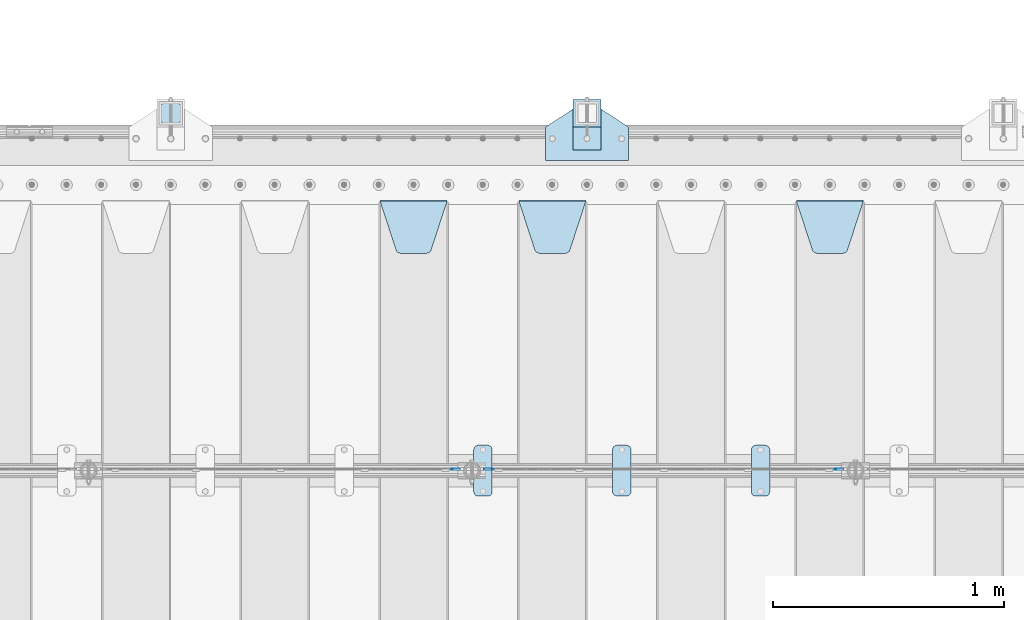
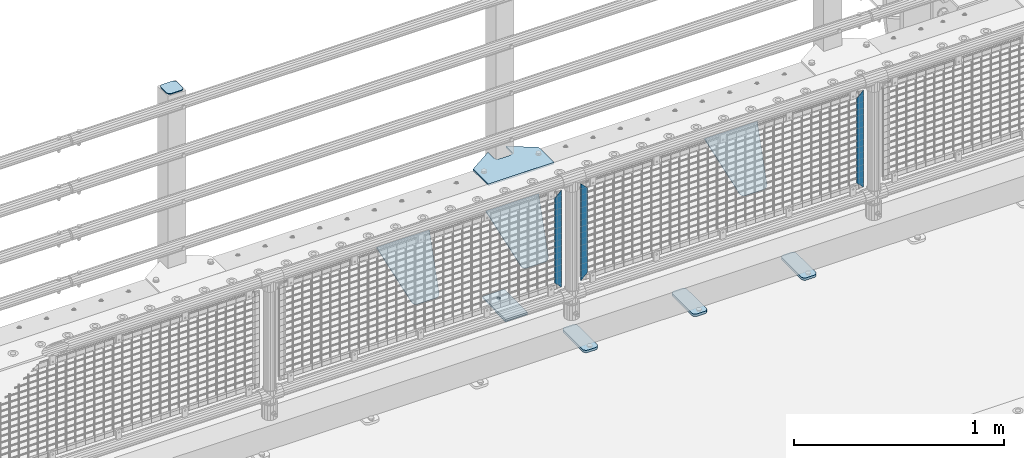
# One storey, part 198 of 219: 13 plates.
"""IFC2X3 building model written with IfcOpenShell, lengths in millimetres."""

from ifc_helpers import new_model, si_unit, frame, origin_with_axes, place, context, subcontext, project, spatial, faceted_brep, material, type_object, element, save


model = new_model("IFC2X3")

# Units and contexts
model_context = context("Model", 3, precision=1e-05, world=origin_with_axes())
body_context = subcontext(model_context, "Body", "Model", "MODEL_VIEW")
ifc_project = project(units=[si_unit("LENGTHUNIT", "METRE", prefix="MILLI"), si_unit("AREAUNIT", "SQUARE_METRE"), si_unit("VOLUMEUNIT", "CUBIC_METRE"), si_unit("MASSUNIT", "GRAM", prefix="KILO"), si_unit("TIMEUNIT", "SECOND"), si_unit("PLANEANGLEUNIT", "RADIAN"), si_unit("SOLIDANGLEUNIT", "STERADIAN"), si_unit("THERMODYNAMICTEMPERATUREUNIT", "DEGREE_CELSIUS"), si_unit("LUMINOUSINTENSITYUNIT", "LUMEN")], contexts=[model_context])

# Site, building, storey
site_placement = place(None, origin_with_axes())
site = spatial("IfcSite", under=ifc_project, at=site_placement, CompositionType="ELEMENT")
building_placement = place(site_placement, origin_with_axes())
building = spatial("IfcBuilding", under=site, at=building_placement, Name="Standard", CompositionType="ELEMENT")
storey_placement = place(building_placement, origin_with_axes())
storey = spatial("IfcBuildingStorey", under=building, at=storey_placement, Name="Undefined", CompositionType="ELEMENT", Elevation=0.0)

# Plates
ifc_material_1 = material(Name="STEEL/S355N")
plate_type_1 = type_object("IfcPlateType", PredefinedType="NOTDEFINED")
plate_1_placement = place(storey_placement, frame((8655.0, 32831.767766956, -1.76776695296758), z_axis=(0.0, -0.707106781186547, -0.707106781186548), x_axis=(1.0, 0.0, 0.0)))
element("IfcPlate", 1, at=plate_1_placement, inside=storey, type_object=plate_type_1, material=ifc_material_1, context=body_context, shape_type="Brep", body=[
    faceted_brep([(0.0, -2.5, 0.0), (69.345504679477, -2.5, 300.171731424834), (69.345504679477, 2.49999999999636, 300.171731424831), (0.0, 2.5, 0.0), (70.9274061199576, -2.50000000000364, 304.8974424154), (70.9274061199576, 2.49999999999636, 304.8974424154), (73.3818627772307, -2.50000000000364, 309.234538108532), (73.3818627772307, 2.49999999999636, 309.234538108532), (76.6187032999569, -2.50000000000364, 313.023683126106), (76.6187032999569, 2.49999999999636, 313.023683126106), (80.5190132704993, -2.50000000000364, 316.125672595372), (80.5190132704993, 2.49999999999636, 316.125672595372), (84.9395038596831, -2.50000000000364, 318.426546230476), (84.9395038596831, 2.5, 318.426546230479), (89.7177759439237, -2.50000000000364, 319.841774983277), (89.7177759439237, 2.5, 319.841774983281), (94.6782862926502, -2.50000000000364, 320.319366455078), (94.6782862926502, 2.49999999999636, 320.319366455078), (195.32171370735, -2.50000000000364, 320.319366455078), (195.32171370735, 2.49999999999636, 320.319366455078), (200.282224056076, -2.50000000000364, 319.841774983277), (200.282224056076, 2.5, 319.841774983281), (205.060496140317, -2.50000000000364, 318.426546230476), (205.060496140317, 2.49999999999636, 318.426546230476), (209.480986729501, -2.50000000000364, 316.125672595372), (209.480986729501, 2.49999999999636, 316.125672595372), (213.381296700043, -2.50000000000364, 313.023683126106), (213.381296700043, 2.49999999999272, 313.023683126106), (216.618137222769, -2.50000000000364, 309.234538108529), (216.618137222769, 2.49999999999636, 309.234538108525), (219.072593880042, -2.50000000000364, 304.8974424154), (219.072593880042, 2.49999999999636, 304.8974424154), (220.654495320523, -2.5, 300.171731424834), (220.654495320523, 2.49999999999636, 300.171731424831), (290.0, -2.50000000000364, 3.63797880709171e-12), (290.0, 2.49999999999636, 0.0)], [[[0, 1, 2, 3]], [[1, 4, 5, 2]], [[4, 6, 7, 5]], [[6, 8, 9, 7]], [[8, 10, 11, 9]], [[10, 12, 13, 11]], [[12, 14, 15, 13]], [[14, 16, 17, 15]], [[16, 18, 19, 17]], [[18, 20, 21, 19]], [[20, 22, 23, 21]], [[22, 24, 25, 23]], [[24, 26, 27, 25]], [[26, 28, 29, 27]], [[28, 30, 31, 29]], [[30, 32, 33, 31]], [[32, 34, 35, 33]], [[34, 0, 3, 35]], [[5, 7, 9, 11, 13, 15, 17, 19, 21, 23, 25, 27, 29, 31, 33, 35, 3, 2]], [[34, 32, 30, 28, 26, 24, 22, 20, 18, 16, 14, 12, 10, 8, 6, 4, 1, 0]]]),
])
plate_2_placement = place(storey_placement, frame((7455.0, 32831.767766956, -1.76776695296758), z_axis=(0.0, -0.707106781186547, -0.707106781186548), x_axis=(1.0, 0.0, 0.0)))
element("IfcPlate", 2, at=plate_2_placement, inside=storey, type_object=plate_type_1, material=ifc_material_1, context=body_context, shape_type="Brep", body=[
    faceted_brep([(0.0, -2.5, 0.0), (69.345504679477, -2.5, 300.171731424834), (69.345504679477, 2.49999999999636, 300.171731424831), (0.0, 2.5, 0.0), (70.9274061199576, -2.50000000000364, 304.8974424154), (70.9274061199576, 2.49999999999636, 304.8974424154), (73.3818627772307, -2.50000000000364, 309.234538108532), (73.3818627772307, 2.49999999999636, 309.234538108532), (76.6187032999569, -2.50000000000364, 313.023683126106), (76.6187032999569, 2.49999999999636, 313.023683126106), (80.5190132704993, -2.50000000000364, 316.125672595372), (80.5190132704993, 2.49999999999636, 316.125672595372), (84.9395038596831, -2.50000000000364, 318.426546230476), (84.9395038596831, 2.5, 318.426546230479), (89.7177759439237, -2.50000000000364, 319.841774983277), (89.7177759439237, 2.5, 319.841774983281), (94.6782862926502, -2.50000000000364, 320.319366455078), (94.6782862926502, 2.49999999999636, 320.319366455078), (195.32171370735, -2.50000000000364, 320.319366455078), (195.32171370735, 2.49999999999636, 320.319366455078), (200.282224056076, -2.50000000000364, 319.841774983277), (200.282224056076, 2.5, 319.841774983281), (205.060496140317, -2.50000000000364, 318.426546230476), (205.060496140317, 2.49999999999636, 318.426546230476), (209.480986729501, -2.50000000000364, 316.125672595372), (209.480986729501, 2.49999999999636, 316.125672595372), (213.381296700043, -2.50000000000364, 313.023683126106), (213.381296700043, 2.49999999999272, 313.023683126106), (216.618137222769, -2.50000000000364, 309.234538108529), (216.618137222769, 2.49999999999636, 309.234538108525), (219.072593880042, -2.50000000000364, 304.8974424154), (219.072593880042, 2.49999999999636, 304.8974424154), (220.654495320523, -2.5, 300.171731424834), (220.654495320523, 2.49999999999636, 300.171731424831), (290.0, -2.50000000000364, 3.63797880709171e-12), (290.0, 2.49999999999636, 0.0)], [[[0, 1, 2, 3]], [[1, 4, 5, 2]], [[4, 6, 7, 5]], [[6, 8, 9, 7]], [[8, 10, 11, 9]], [[10, 12, 13, 11]], [[12, 14, 15, 13]], [[14, 16, 17, 15]], [[16, 18, 19, 17]], [[18, 20, 21, 19]], [[20, 22, 23, 21]], [[22, 24, 25, 23]], [[24, 26, 27, 25]], [[26, 28, 29, 27]], [[28, 30, 31, 29]], [[30, 32, 33, 31]], [[32, 34, 35, 33]], [[34, 0, 3, 35]], [[5, 7, 9, 11, 13, 15, 17, 19, 21, 23, 25, 27, 29, 31, 33, 35, 3, 2]], [[34, 32, 30, 28, 26, 24, 22, 20, 18, 16, 14, 12, 10, 8, 6, 4, 1, 0]]]),
])
plate_3_placement = place(storey_placement, frame((6855.0, 32831.767766956, -1.76776695296758), z_axis=(0.0, -0.707106781186547, -0.707106781186548), x_axis=(1.0, 0.0, 0.0)))
element("IfcPlate", 3, at=plate_3_placement, inside=storey, type_object=plate_type_1, material=ifc_material_1, context=body_context, shape_type="Brep", body=[
    faceted_brep([(0.0, -2.5, 0.0), (69.345504679477, -2.5, 300.171731424834), (69.345504679477, 2.49999999999636, 300.171731424831), (0.0, 2.5, 0.0), (70.9274061199576, -2.50000000000364, 304.8974424154), (70.9274061199576, 2.49999999999636, 304.8974424154), (73.3818627772307, -2.50000000000364, 309.234538108532), (73.3818627772307, 2.49999999999636, 309.234538108532), (76.6187032999569, -2.50000000000364, 313.023683126106), (76.6187032999569, 2.49999999999636, 313.023683126106), (80.5190132704993, -2.50000000000364, 316.125672595372), (80.5190132704993, 2.49999999999636, 316.125672595372), (84.9395038596831, -2.50000000000364, 318.426546230476), (84.9395038596831, 2.5, 318.426546230479), (89.7177759439237, -2.50000000000364, 319.841774983277), (89.7177759439237, 2.5, 319.841774983281), (94.6782862926502, -2.50000000000364, 320.319366455078), (94.6782862926502, 2.49999999999636, 320.319366455078), (195.32171370735, -2.50000000000364, 320.319366455078), (195.32171370735, 2.49999999999636, 320.319366455078), (200.282224056076, -2.50000000000364, 319.841774983277), (200.282224056076, 2.5, 319.841774983281), (205.060496140317, -2.50000000000364, 318.426546230476), (205.060496140317, 2.49999999999636, 318.426546230476), (209.480986729501, -2.50000000000364, 316.125672595372), (209.480986729501, 2.49999999999636, 316.125672595372), (213.381296700043, -2.50000000000364, 313.023683126106), (213.381296700043, 2.49999999999272, 313.023683126106), (216.618137222769, -2.50000000000364, 309.234538108529), (216.618137222769, 2.49999999999636, 309.234538108525), (219.072593880042, -2.50000000000364, 304.8974424154), (219.072593880042, 2.49999999999636, 304.8974424154), (220.654495320523, -2.5, 300.171731424834), (220.654495320523, 2.49999999999636, 300.171731424831), (290.0, -2.50000000000364, 3.63797880709171e-12), (290.0, 2.49999999999636, 0.0)], [[[0, 1, 2, 3]], [[1, 4, 5, 2]], [[4, 6, 7, 5]], [[6, 8, 9, 7]], [[8, 10, 11, 9]], [[10, 12, 13, 11]], [[12, 14, 15, 13]], [[14, 16, 17, 15]], [[16, 18, 19, 17]], [[18, 20, 21, 19]], [[20, 22, 23, 21]], [[22, 24, 25, 23]], [[24, 26, 27, 25]], [[26, 28, 29, 27]], [[28, 30, 31, 29]], [[30, 32, 33, 31]], [[32, 34, 35, 33]], [[34, 0, 3, 35]], [[5, 7, 9, 11, 13, 15, 17, 19, 21, 23, 25, 27, 29, 31, 33, 35, 3, 2]], [[34, 32, 30, 28, 26, 24, 22, 20, 18, 16, 14, 12, 10, 8, 6, 4, 1, 0]]]),
])
ifc_material_2 = material(Name="Misc_Undefined")
plate_type_2 = type_object("IfcPlateType", PredefinedType="NOTDEFINED")
plate_4_placement = place(storey_placement, frame((7341.50971354097, 31670.5, 879.519963133601), z_axis=(-0.707008801899319, 0.0, -0.707204746899291), x_axis=(-0.707204746899285, 0.0, 0.707008801899324)))
element("IfcPlate", 4, at=plate_4_placement, inside=storey, type_object=plate_type_2, material=ifc_material_2, context=body_context, shape_type="Brep", body=[
    faceted_brep([(0.0, -1.5, -5.6843418860808e-14), (-348.552185058593, -1.5, 348.655029296875), (-348.552185058593, 1.5, 348.655029296875), (0.0, 1.5, -5.6843418860808e-14), (-348.544891357421, -1.5, 398.152496337892), (-348.544891357421, 1.5, 398.152496337892), (49.5043945312482, -1.5, 7.6397554948926e-11), (49.5043945312482, 1.5, 7.6397554948926e-11)], [[[0, 1, 2, 3]], [[1, 4, 5, 2]], [[4, 6, 7, 5]], [[6, 0, 3, 7]], [[5, 7, 3, 2]], [[6, 4, 1, 0]]]),
])
for number, where, z_axis, x_axis in (
    (5, (8822.49968748361, 31670.5, 879.52), (0.707103624179499, 0.0, -0.707109938179501), (0.707109938179499, 0.0, 0.707103624179502)),
    (6, (7164.49968748361, 31670.5, 879.52), (0.707103624179499, 0.0, -0.707109938179501), (0.707109938179499, 0.0, 0.707103624179502)),
):
    element("IfcPlate", number, at=place(storey_placement, frame(where, z_axis=z_axis, x_axis=x_axis)), inside=storey, type_object=plate_type_2, material=ifc_material_2, context=body_context, shape_type="Brep", body=[
        faceted_brep([(0.0, -1.5, -5.6843418860808e-14), (-348.605163574219, -1.5, 348.602081298829), (-348.605163574219, 1.5, 348.602081298829), (0.0, 1.5, -5.6843418860808e-14), (-348.605163574217, -1.5, 398.0993347168), (-348.605163574217, 1.5, 398.0993347168), (49.4976959228516, -1.5, -1.0550138540566e-10), (49.4976959228516, 1.5, -1.0550138540566e-10)], [[[0, 1, 2, 3]], [[1, 4, 5, 2]], [[4, 6, 7, 5]], [[6, 0, 3, 7]], [[5, 7, 3, 2]], [[6, 4, 1, 0]]]),
    ])
ifc_material_3 = material(Name="STEEL/S355J2")
plate_type_3 = type_object("IfcPlateType", PredefinedType="NOTDEFINED")
plate_5_placement = place(storey_placement, frame((8460.0, 31774.5, 21.0199999999977), z_axis=(1.0, 0.0, 0.0), x_axis=(0.0, -1.0, 0.0)))
element("IfcPlate", 7, at=plate_5_placement, inside=storey, type_object=plate_type_3, material=ifc_material_3, context=body_context, shape_type="Brep", body=[
    faceted_brep([(0.0, -7.0, 20.0), (0.0, -7.0, 60.0), (0.0, 7.0, 60.0), (0.0, 7.0, 20.0), (0.384294391937146, -7.0, 63.9018064403226), (0.384294391937146, 7.0, 63.9018064403226), (1.52240934977453, -7.0, 67.6536686473009), (1.52240934977453, 7.0, 67.6536686473009), (3.37060775395003, -7.0, 71.1114046603925), (3.37060775395003, 7.0, 71.1114046603925), (5.8578643762703, -7.0, 74.1421356237315), (5.8578643762703, 7.0, 74.1421356237315), (8.88859533960931, -7.0, 76.6293922460518), (8.88859533960931, 7.0, 76.6293922460518), (12.3463313526991, -7.0, 78.4775906502255), (12.3463313526991, 7.0, 78.4775906502255), (16.0981935596792, -7.0, 79.6157056080647), (16.0981935596792, 7.0, 79.6157056080647), (20.0, -7.0, 80.0), (20.0, 7.0, 80.0), (200.0, -7.0, 80.0), (200.0, 7.0, 80.0), (203.901806440321, -7.0, 79.6157056080647), (203.901806440321, 7.0, 79.6157056080647), (207.653668647301, -7.0, 78.4775906502255), (207.653668647301, 7.0, 78.4775906502255), (211.111404660391, -7.0, 76.6293922460518), (211.111404660391, 7.0, 76.6293922460518), (214.14213562373, -7.0, 74.1421356237315), (214.14213562373, 7.0, 74.1421356237315), (216.62939224605, -7.0, 71.1114046603925), (216.62939224605, 7.0, 71.1114046603925), (218.477590650225, -7.0, 67.6536686473009), (218.477590650225, 7.0, 67.6536686473009), (219.615705608063, -7.0, 63.9018064403226), (219.615705608063, 7.0, 63.9018064403226), (220.0, -7.0, 60.0), (220.0, 7.0, 60.0), (220.0, -7.0, 20.0), (220.0, 7.0, 20.0), (219.615705608063, -7.0, 16.0981935596774), (219.615705608063, 7.0, 16.0981935596774), (218.477590650225, -7.0, 12.3463313526991), (218.477590650225, 7.0, 12.3463313526991), (216.62939224605, -7.0, 8.88859533960749), (216.62939224605, 7.0, 8.88859533960749), (214.14213562373, -7.0, 5.85786437626848), (214.14213562373, 7.0, 5.85786437626848), (211.111404660391, -7.0, 3.37060775394821), (211.111404660391, 7.0, 3.37060775394821), (207.653668647301, -7.0, 1.52240934977453), (207.653668647301, 7.0, 1.52240934977453), (203.901806440321, -7.0, 0.384294391935327), (203.901806440321, 7.0, 0.384294391935327), (200.0, -7.0, 0.0), (200.0, 7.0, 0.0), (20.0, -7.0, 0.0), (20.0, 7.0, 0.0), (16.0981935596792, -7.0, 0.384294391935327), (16.0981935596792, 7.0, 0.384294391935327), (12.3463313526991, -7.0, 1.52240934977453), (12.3463313526991, 7.0, 1.52240934977453), (8.88859533960931, -7.0, 3.37060775394821), (8.88859533960931, 7.0, 3.37060775394821), (5.8578643762703, -7.0, 5.85786437626848), (5.8578643762703, 7.0, 5.85786437626848), (3.37060775395003, -7.0, 8.88859533960749), (3.37060775395003, 7.0, 8.88859533960749), (1.52240934977453, -7.0, 12.3463313526991), (1.52240934977453, 7.0, 12.3463313526991), (0.384294391937146, -7.0, 16.0981935596774), (0.384294391937146, 7.0, 16.0981935596774)], [[[0, 1, 2, 3]], [[1, 4, 5, 2]], [[4, 6, 7, 5]], [[6, 8, 9, 7]], [[8, 10, 11, 9]], [[10, 12, 13, 11]], [[12, 14, 15, 13]], [[14, 16, 17, 15]], [[16, 18, 19, 17]], [[18, 20, 21, 19]], [[20, 22, 23, 21]], [[22, 24, 25, 23]], [[24, 26, 27, 25]], [[26, 28, 29, 27]], [[28, 30, 31, 29]], [[30, 32, 33, 31]], [[32, 34, 35, 33]], [[34, 36, 37, 35]], [[36, 38, 39, 37]], [[38, 40, 41, 39]], [[40, 42, 43, 41]], [[42, 44, 45, 43]], [[44, 46, 47, 45]], [[46, 48, 49, 47]], [[48, 50, 51, 49]], [[50, 52, 53, 51]], [[52, 54, 55, 53]], [[54, 56, 57, 55]], [[56, 58, 59, 57]], [[58, 60, 61, 59]], [[60, 62, 63, 61]], [[62, 64, 65, 63]], [[64, 66, 67, 65]], [[66, 68, 69, 67]], [[68, 70, 71, 69]], [[70, 0, 3, 71]], [[5, 7, 9, 11, 13, 15, 17, 19, 21, 23, 25, 27, 29, 31, 33, 35, 37, 39, 41, 43, 45, 47, 49, 51, 53, 55, 57, 59, 61, 63, 65, 67, 69, 71, 3, 2]], [[70, 68, 66, 64, 62, 60, 58, 56, 54, 52, 50, 48, 46, 44, 42, 40, 38, 36, 34, 32, 30, 28, 26, 24, 22, 20, 18, 16, 14, 12, 10, 8, 6, 4, 1, 0]]]),
])
plate_6_placement = place(storey_placement, frame((7860.0, 31774.5, 21.0199999999977), z_axis=(1.0, 0.0, 0.0), x_axis=(0.0, -1.0, 0.0)))
element("IfcPlate", 8, at=plate_6_placement, inside=storey, type_object=plate_type_3, material=ifc_material_3, context=body_context, shape_type="Brep", body=[
    faceted_brep([(0.0, -7.0, 20.0), (0.0, -7.0, 60.0), (0.0, 7.0, 60.0), (0.0, 7.0, 20.0), (0.384294391937146, -7.0, 63.9018064403226), (0.384294391937146, 7.0, 63.9018064403226), (1.52240934977453, -7.0, 67.6536686473009), (1.52240934977453, 7.0, 67.6536686473009), (3.37060775395003, -7.0, 71.1114046603925), (3.37060775395003, 7.0, 71.1114046603925), (5.8578643762703, -7.0, 74.1421356237315), (5.8578643762703, 7.0, 74.1421356237315), (8.88859533960931, -7.0, 76.6293922460518), (8.88859533960931, 7.0, 76.6293922460518), (12.3463313526991, -7.0, 78.4775906502255), (12.3463313526991, 7.0, 78.4775906502255), (16.0981935596792, -7.0, 79.6157056080647), (16.0981935596792, 7.0, 79.6157056080647), (20.0, -7.0, 80.0), (20.0, 7.0, 80.0), (200.0, -7.0, 80.0), (200.0, 7.0, 80.0), (203.901806440321, -7.0, 79.6157056080647), (203.901806440321, 7.0, 79.6157056080647), (207.653668647301, -7.0, 78.4775906502255), (207.653668647301, 7.0, 78.4775906502255), (211.111404660391, -7.0, 76.6293922460518), (211.111404660391, 7.0, 76.6293922460518), (214.14213562373, -7.0, 74.1421356237315), (214.14213562373, 7.0, 74.1421356237315), (216.62939224605, -7.0, 71.1114046603925), (216.62939224605, 7.0, 71.1114046603925), (218.477590650225, -7.0, 67.6536686473009), (218.477590650225, 7.0, 67.6536686473009), (219.615705608063, -7.0, 63.9018064403226), (219.615705608063, 7.0, 63.9018064403226), (220.0, -7.0, 60.0), (220.0, 7.0, 60.0), (220.0, -7.0, 20.0), (220.0, 7.0, 20.0), (219.615705608063, -7.0, 16.0981935596774), (219.615705608063, 7.0, 16.0981935596774), (218.477590650225, -7.0, 12.3463313526991), (218.477590650225, 7.0, 12.3463313526991), (216.62939224605, -7.0, 8.88859533960749), (216.62939224605, 7.0, 8.88859533960749), (214.14213562373, -7.0, 5.85786437626848), (214.14213562373, 7.0, 5.85786437626848), (211.111404660391, -7.0, 3.37060775394821), (211.111404660391, 7.0, 3.37060775394821), (207.653668647301, -7.0, 1.52240934977453), (207.653668647301, 7.0, 1.52240934977453), (203.901806440321, -7.0, 0.384294391935327), (203.901806440321, 7.0, 0.384294391935327), (200.0, -7.0, 0.0), (200.0, 7.0, 0.0), (20.0, -7.0, 0.0), (20.0, 7.0, 0.0), (16.0981935596792, -7.0, 0.384294391935327), (16.0981935596792, 7.0, 0.384294391935327), (12.3463313526991, -7.0, 1.52240934977453), (12.3463313526991, 7.0, 1.52240934977453), (8.88859533960931, -7.0, 3.37060775394821), (8.88859533960931, 7.0, 3.37060775394821), (5.8578643762703, -7.0, 5.85786437626848), (5.8578643762703, 7.0, 5.85786437626848), (3.37060775395003, -7.0, 8.88859533960749), (3.37060775395003, 7.0, 8.88859533960749), (1.52240934977453, -7.0, 12.3463313526991), (1.52240934977453, 7.0, 12.3463313526991), (0.384294391937146, -7.0, 16.0981935596774), (0.384294391937146, 7.0, 16.0981935596774)], [[[0, 1, 2, 3]], [[1, 4, 5, 2]], [[4, 6, 7, 5]], [[6, 8, 9, 7]], [[8, 10, 11, 9]], [[10, 12, 13, 11]], [[12, 14, 15, 13]], [[14, 16, 17, 15]], [[16, 18, 19, 17]], [[18, 20, 21, 19]], [[20, 22, 23, 21]], [[22, 24, 25, 23]], [[24, 26, 27, 25]], [[26, 28, 29, 27]], [[28, 30, 31, 29]], [[30, 32, 33, 31]], [[32, 34, 35, 33]], [[34, 36, 37, 35]], [[36, 38, 39, 37]], [[38, 40, 41, 39]], [[40, 42, 43, 41]], [[42, 44, 45, 43]], [[44, 46, 47, 45]], [[46, 48, 49, 47]], [[48, 50, 51, 49]], [[50, 52, 53, 51]], [[52, 54, 55, 53]], [[54, 56, 57, 55]], [[56, 58, 59, 57]], [[58, 60, 61, 59]], [[60, 62, 63, 61]], [[62, 64, 65, 63]], [[64, 66, 67, 65]], [[66, 68, 69, 67]], [[68, 70, 71, 69]], [[70, 0, 3, 71]], [[5, 7, 9, 11, 13, 15, 17, 19, 21, 23, 25, 27, 29, 31, 33, 35, 37, 39, 41, 43, 45, 47, 49, 51, 53, 55, 57, 59, 61, 63, 65, 67, 69, 71, 3, 2]], [[70, 68, 66, 64, 62, 60, 58, 56, 54, 52, 50, 48, 46, 44, 42, 40, 38, 36, 34, 32, 30, 28, 26, 24, 22, 20, 18, 16, 14, 12, 10, 8, 6, 4, 1, 0]]]),
])
plate_7_placement = place(storey_placement, frame((7260.0, 31774.5, 21.0199999999977), z_axis=(1.0, 0.0, 0.0), x_axis=(0.0, -1.0, 0.0)))
element("IfcPlate", 9, at=plate_7_placement, inside=storey, type_object=plate_type_3, material=ifc_material_3, context=body_context, shape_type="Brep", body=[
    faceted_brep([(0.0, -7.0, 20.0), (0.0, -7.0, 60.0), (0.0, 7.0, 60.0), (0.0, 7.0, 20.0), (0.384294391937146, -7.0, 63.9018064403226), (0.384294391937146, 7.0, 63.9018064403226), (1.52240934977453, -7.0, 67.6536686473009), (1.52240934977453, 7.0, 67.6536686473009), (3.37060775395003, -7.0, 71.1114046603925), (3.37060775395003, 7.0, 71.1114046603925), (5.8578643762703, -7.0, 74.1421356237315), (5.8578643762703, 7.0, 74.1421356237315), (8.88859533960931, -7.0, 76.6293922460518), (8.88859533960931, 7.0, 76.6293922460518), (12.3463313526991, -7.0, 78.4775906502255), (12.3463313526991, 7.0, 78.4775906502255), (16.0981935596792, -7.0, 79.6157056080647), (16.0981935596792, 7.0, 79.6157056080647), (20.0, -7.0, 80.0), (20.0, 7.0, 80.0), (200.0, -7.0, 80.0), (200.0, 7.0, 80.0), (203.901806440321, -7.0, 79.6157056080647), (203.901806440321, 7.0, 79.6157056080647), (207.653668647301, -7.0, 78.4775906502255), (207.653668647301, 7.0, 78.4775906502255), (211.111404660391, -7.0, 76.6293922460518), (211.111404660391, 7.0, 76.6293922460518), (214.14213562373, -7.0, 74.1421356237315), (214.14213562373, 7.0, 74.1421356237315), (216.62939224605, -7.0, 71.1114046603925), (216.62939224605, 7.0, 71.1114046603925), (218.477590650225, -7.0, 67.6536686473009), (218.477590650225, 7.0, 67.6536686473009), (219.615705608063, -7.0, 63.9018064403226), (219.615705608063, 7.0, 63.9018064403226), (220.0, -7.0, 60.0), (220.0, 7.0, 60.0), (220.0, -7.0, 20.0), (220.0, 7.0, 20.0), (219.615705608063, -7.0, 16.0981935596774), (219.615705608063, 7.0, 16.0981935596774), (218.477590650225, -7.0, 12.3463313526991), (218.477590650225, 7.0, 12.3463313526991), (216.62939224605, -7.0, 8.88859533960749), (216.62939224605, 7.0, 8.88859533960749), (214.14213562373, -7.0, 5.85786437626848), (214.14213562373, 7.0, 5.85786437626848), (211.111404660391, -7.0, 3.37060775394821), (211.111404660391, 7.0, 3.37060775394821), (207.653668647301, -7.0, 1.52240934977453), (207.653668647301, 7.0, 1.52240934977453), (203.901806440321, -7.0, 0.384294391935327), (203.901806440321, 7.0, 0.384294391935327), (200.0, -7.0, 0.0), (200.0, 7.0, 0.0), (20.0, -7.0, 0.0), (20.0, 7.0, 0.0), (16.0981935596792, -7.0, 0.384294391935327), (16.0981935596792, 7.0, 0.384294391935327), (12.3463313526991, -7.0, 1.52240934977453), (12.3463313526991, 7.0, 1.52240934977453), (8.88859533960931, -7.0, 3.37060775394821), (8.88859533960931, 7.0, 3.37060775394821), (5.8578643762703, -7.0, 5.85786437626848), (5.8578643762703, 7.0, 5.85786437626848), (3.37060775395003, -7.0, 8.88859533960749), (3.37060775395003, 7.0, 8.88859533960749), (1.52240934977453, -7.0, 12.3463313526991), (1.52240934977453, 7.0, 12.3463313526991), (0.384294391937146, -7.0, 16.0981935596774), (0.384294391937146, 7.0, 16.0981935596774)], [[[0, 1, 2, 3]], [[1, 4, 5, 2]], [[4, 6, 7, 5]], [[6, 8, 9, 7]], [[8, 10, 11, 9]], [[10, 12, 13, 11]], [[12, 14, 15, 13]], [[14, 16, 17, 15]], [[16, 18, 19, 17]], [[18, 20, 21, 19]], [[20, 22, 23, 21]], [[22, 24, 25, 23]], [[24, 26, 27, 25]], [[26, 28, 29, 27]], [[28, 30, 31, 29]], [[30, 32, 33, 31]], [[32, 34, 35, 33]], [[34, 36, 37, 35]], [[36, 38, 39, 37]], [[38, 40, 41, 39]], [[40, 42, 43, 41]], [[42, 44, 45, 43]], [[44, 46, 47, 45]], [[46, 48, 49, 47]], [[48, 50, 51, 49]], [[50, 52, 53, 51]], [[52, 54, 55, 53]], [[54, 56, 57, 55]], [[56, 58, 59, 57]], [[58, 60, 61, 59]], [[60, 62, 63, 61]], [[62, 64, 65, 63]], [[64, 66, 67, 65]], [[66, 68, 69, 67]], [[68, 70, 71, 69]], [[70, 0, 3, 71]], [[5, 7, 9, 11, 13, 15, 17, 19, 21, 23, 25, 27, 29, 31, 33, 35, 37, 39, 41, 43, 45, 47, 49, 51, 53, 55, 57, 59, 61, 63, 65, 67, 69, 71, 3, 2]], [[70, 68, 66, 64, 62, 60, 58, 56, 54, 52, 50, 48, 46, 44, 42, 40, 38, 36, 34, 32, 30, 28, 26, 24, 22, 20, 18, 16, 14, 12, 10, 8, 6, 4, 1, 0]]]),
])
plate_type_4 = type_object("IfcPlateType", PredefinedType="NOTDEFINED")
plate_8_placement = place(storey_placement, frame((7570.0, 33005.0, 5.00000000004911), z_axis=(0.0, 1.0, 0.0), x_axis=(1.0, 0.0, 0.0)))
element("IfcPlate", 10, at=plate_8_placement, inside=storey, type_object=plate_type_4, material=ifc_material_3, context=body_context, shape_type="Brep", body=[
    faceted_brep([(0.0, -5.0, 0.0), (2.31396552408114e-06, -5.0, 145.0), (2.31396552408114e-06, 5.0, 145.0), (0.0, 5.0, 0.0), (130.0, -5.0, 230.0), (130.0, 5.0, 230.0), (130.0, -5.0, 180.0), (130.0, 5.0, 180.0), (130.48036798992, -5.0, 175.122741949599), (130.48036798992, 5.0, 175.122741949599), (131.903011687218, -5.0, 170.432914190875), (131.903011687218, 5.0, 170.432914190875), (134.213259692437, -5.0, 166.110744174512), (134.213259692437, 5.0, 166.110744174512), (137.322330470337, -5.0, 162.322330470335), (137.322330470337, 5.0, 162.322330470335), (141.11074417451, -5.0, 159.213259692435), (141.11074417451, 5.0, 159.213259692435), (145.432914190873, -5.0, 156.903011687216), (145.432914190873, 5.0, 156.903011687216), (150.122741949597, -5.0, 155.48036798992), (150.122741949597, 5.0, 155.48036798992), (155.0, -5.0, 155.0), (155.0, 5.0, 155.0), (205.0, -5.0, 155.0), (205.0, 5.0, 155.0), (209.877258050403, -5.0, 155.48036798992), (209.877258050403, 5.0, 155.48036798992), (214.567085809127, -5.0, 156.903011687216), (214.567085809127, 5.0, 156.903011687216), (218.88925582549, -5.0, 159.213259692435), (218.88925582549, 5.0, 159.213259692435), (222.677669529663, -5.0, 162.322330470335), (222.677669529663, 5.0, 162.322330470335), (225.786740307563, -5.0, 166.110744174512), (225.786740307563, 5.0, 166.110744174512), (228.096988312782, -5.0, 170.432914190875), (228.096988312782, 5.0, 170.432914190875), (229.51963201008, -5.0, 175.122741949599), (229.51963201008, 5.0, 175.122741949599), (230.0, -5.0, 180.0), (230.0, 5.0, 180.0), (230.0, -5.0, 230.0), (230.0, 5.0, 230.0), (360.0, -5.0, 145.0), (360.0, 5.0, 145.0), (360.0, -5.0, -7.27595761418343e-12), (360.0, 5.0, -7.27595761418343e-12)], [[[0, 1, 2, 3]], [[1, 4, 5, 2]], [[4, 6, 7, 5]], [[6, 8, 9, 7]], [[8, 10, 11, 9]], [[10, 12, 13, 11]], [[12, 14, 15, 13]], [[14, 16, 17, 15]], [[16, 18, 19, 17]], [[18, 20, 21, 19]], [[20, 22, 23, 21]], [[22, 24, 25, 23]], [[24, 26, 27, 25]], [[26, 28, 29, 27]], [[28, 30, 31, 29]], [[30, 32, 33, 31]], [[32, 34, 35, 33]], [[34, 36, 37, 35]], [[36, 38, 39, 37]], [[38, 40, 41, 39]], [[40, 42, 43, 41]], [[42, 44, 45, 43]], [[44, 46, 47, 45]], [[46, 0, 3, 47]], [[5, 7, 9, 11, 13, 15, 17, 19, 21, 23, 25, 27, 29, 31, 33, 35, 37, 39, 41, 43, 45, 47, 3, 2]], [[46, 44, 42, 40, 38, 36, 34, 32, 30, 28, 26, 24, 22, 20, 18, 16, 14, 12, 10, 8, 6, 4, 1, 0]]]),
])
plate_type_5 = type_object("IfcPlateType", PredefinedType="NOTDEFINED")
plate_9_placement = place(storey_placement, frame((7690.00000000014, 33050.0000000002, -850.000000000002), z_axis=(0.0, 1.0, 0.0), x_axis=(1.0, 0.0, 0.0)))
element("IfcPlate", 11, at=plate_9_placement, inside=storey, type_object=plate_type_5, material=ifc_material_3, context=body_context, shape_type="Brep", body=[
    faceted_brep([(66.3639610305399, -5.0, 163.636038969111), (66.3639610305399, 5.0, 163.636038969111), (59.9999999998618, 5.0, 160.999999999789), (59.9999999998618, -5.0, 160.999999999789), (53.6360389691836, 5.0, 163.636038969111), (53.6360389691836, -5.0, 163.636038969111), (50.9999999998618, 5.0, 169.999999999789), (50.9999999998618, -5.0, 169.999999999789), (53.6360389691836, 5.0, 176.363961030467), (53.6360389691836, -5.0, 176.363961030467), (59.9999999998618, 5.0, 178.999999999789), (59.9999999998618, -5.0, 178.999999999789), (66.3639610305399, 5.0, 176.363961030467), (66.3639610305399, -5.0, 176.363961030467), (68.9999999998618, 5.0, 169.999999999789), (68.9999999998618, -5.0, 169.999999999789), (120.0, -5.0, 0.0), (120.0, -5.0, 220.0), (0.0, -5.0, 220.0), (0.0, -5.0, 0.0), (0.0, 5.0, 0.0), (120.0, 5.0, 0.0), (120.0, 5.0, 220.0), (0.0, 5.0, 220.0)], [[[0, 1, 2, 3]], [[3, 2, 4, 5]], [[5, 4, 6, 7]], [[7, 6, 8, 9]], [[9, 8, 10, 11]], [[11, 10, 12, 13]], [[13, 12, 14, 15]], [[15, 14, 1, 0]], [[16, 17, 18, 19], [3, 5, 7, 9, 11, 13, 15, 0]], [[16, 19, 20, 21]], [[17, 16, 21, 22]], [[18, 17, 22, 23]], [[19, 18, 23, 20]], [[22, 21, 20, 23], [10, 8, 6, 4, 2, 1, 14, 12]]]),
])
plate_type_6 = type_object("IfcPlateType", PredefinedType="NOTDEFINED")
plate_10_placement = place(storey_placement, frame((5994.00000000013, 33166.0000000002, 1012.50000000001), z_axis=(0.0, 1.0, 0.0), x_axis=(-1.0, 0.0, 0.0)))
element("IfcPlate", 12, at=plate_10_placement, inside=storey, type_object=plate_type_6, material=ifc_material_3, context=body_context, shape_type="Brep", body=[
    faceted_brep([(0.0, -2.5, 19.0), (0.0, -2.5, 69.0), (0.0, 2.5, 69.0), (0.0, 2.5, 19.0), (0.476369668545885, -2.5, 73.2278977451715), (0.476369668545885, 2.5, 73.2278977451715), (1.88159150985484, -2.5, 77.2437910432345), (1.88159150985484, 2.5, 77.2437910432345), (4.14520183310742, -2.5, 80.8463062353185), (4.14520183310742, 2.5, 80.8463062353185), (7.15369376468334, -2.5, 83.8547981668889), (7.15369376468334, 2.5, 83.8547981668889), (10.7562089567673, -2.5, 86.118408490147), (10.7562089567673, 2.5, 86.118408490147), (14.7721022548303, -2.5, 87.5236303314523), (14.7721022548303, 2.5, 87.5236303314523), (19.0, -2.5, 88.0), (19.0, 2.5, 88.0), (69.0, -2.5, 88.0), (69.0, 2.5, 88.0), (73.2278977451697, -2.5, 87.5236303314523), (73.2278977451697, 2.5, 87.5236303314523), (77.2437910432327, -2.5, 86.118408490147), (77.2437910432327, 2.5, 86.118408490147), (80.8463062353167, -2.5, 83.8547981668889), (80.8463062353167, 2.5, 83.8547981668889), (83.8547981668926, -2.5, 80.8463062353185), (83.8547981668926, 2.5, 80.8463062353185), (86.1184084901452, -2.5, 77.2437910432345), (86.1184084901452, 2.5, 77.2437910432345), (87.5236303314541, -2.5, 73.2278977451715), (87.5236303314541, 2.5, 73.2278977451715), (88.0, -2.5, 69.0), (88.0, 2.5, 69.0), (88.0, -2.5, 19.0), (88.0, 2.5, 19.0), (87.5236303314541, -2.5, 14.7721022548285), (87.5236303314541, 2.5, 14.7721022548285), (86.1184084901452, -2.5, 10.7562089567655), (86.1184084901452, 2.5, 10.7562089567655), (83.8547981668926, -2.5, 7.15369376468152), (83.8547981668926, 2.5, 7.15369376468152), (80.8463062353167, -2.5, 4.14520183311106), (80.8463062353167, 2.5, 4.14520183311106), (77.2437910432345, -2.5, 1.88159150985302), (77.2437910432345, 2.5, 1.88159150985302), (73.2278977451697, -2.5, 0.476369668547704), (73.2278977451697, 2.5, 0.476369668547704), (69.0, -2.5, 0.0), (69.0, 2.5, 0.0), (19.0, -2.5, 0.0), (19.0, 2.5, 0.0), (14.7721022548303, -2.5, 0.476369668547704), (14.7721022548303, 2.5, 0.476369668547704), (10.7562089567673, -2.5, 1.88159150985302), (10.7562089567673, 2.5, 1.88159150985302), (7.15369376468334, -2.5, 4.14520183311106), (7.15369376468334, 2.5, 4.14520183311106), (4.14520183310742, -2.5, 7.15369376468152), (4.14520183310742, 2.5, 7.15369376468152), (1.88159150985484, -2.5, 10.7562089567655), (1.88159150985484, 2.5, 10.7562089567655), (0.476369668545885, -2.5, 14.7721022548285), (0.476369668545885, 2.5, 14.7721022548285)], [[[0, 1, 2, 3]], [[1, 4, 5, 2]], [[4, 6, 7, 5]], [[6, 8, 9, 7]], [[8, 10, 11, 9]], [[10, 12, 13, 11]], [[12, 14, 15, 13]], [[14, 16, 17, 15]], [[16, 18, 19, 17]], [[18, 20, 21, 19]], [[20, 22, 23, 21]], [[22, 24, 25, 23]], [[24, 26, 27, 25]], [[26, 28, 29, 27]], [[28, 30, 31, 29]], [[30, 32, 33, 31]], [[32, 34, 35, 33]], [[34, 36, 37, 35]], [[36, 38, 39, 37]], [[38, 40, 41, 39]], [[40, 42, 43, 41]], [[42, 44, 45, 43]], [[44, 46, 47, 45]], [[46, 48, 49, 47]], [[48, 50, 51, 49]], [[50, 52, 53, 51]], [[52, 54, 55, 53]], [[54, 56, 57, 55]], [[56, 58, 59, 57]], [[58, 60, 61, 59]], [[60, 62, 63, 61]], [[62, 0, 3, 63]], [[5, 7, 9, 11, 13, 15, 17, 19, 21, 23, 25, 27, 29, 31, 33, 35, 37, 39, 41, 43, 45, 47, 49, 51, 53, 55, 57, 59, 61, 63, 3, 2]], [[62, 60, 58, 56, 54, 52, 50, 48, 46, 44, 42, 40, 38, 36, 34, 32, 30, 28, 26, 24, 22, 20, 18, 16, 14, 12, 10, 8, 6, 4, 1, 0]]]),
])
plate_type_7 = type_object("IfcPlateType", PredefinedType="NOTDEFINED")
plate_11_placement = place(storey_placement, frame((7690.00000000014, 33050.0000000002, -857.500000000002), z_axis=(0.0, 1.0, 0.0), x_axis=(1.0, 0.0, 0.0)))
element("IfcPlate", 13, at=plate_11_placement, inside=storey, type_object=plate_type_7, material=ifc_material_3, context=body_context, shape_type="Brep", body=[
    faceted_brep([(0.0, -2.5, 0.0), (0.0, -2.5, 100.0), (0.0, 2.5, 100.0), (0.0, 2.5, 0.0), (120.0, -2.5, 100.0), (120.0, 2.5, 100.0), (120.0, -2.5, 0.0), (120.0, 2.5, 0.0)], [[[0, 1, 2, 3]], [[1, 4, 5, 2]], [[4, 6, 7, 5]], [[6, 0, 3, 7]], [[5, 7, 3, 2]], [[6, 4, 1, 0]]]),
])

save(model, "model.ifc")
